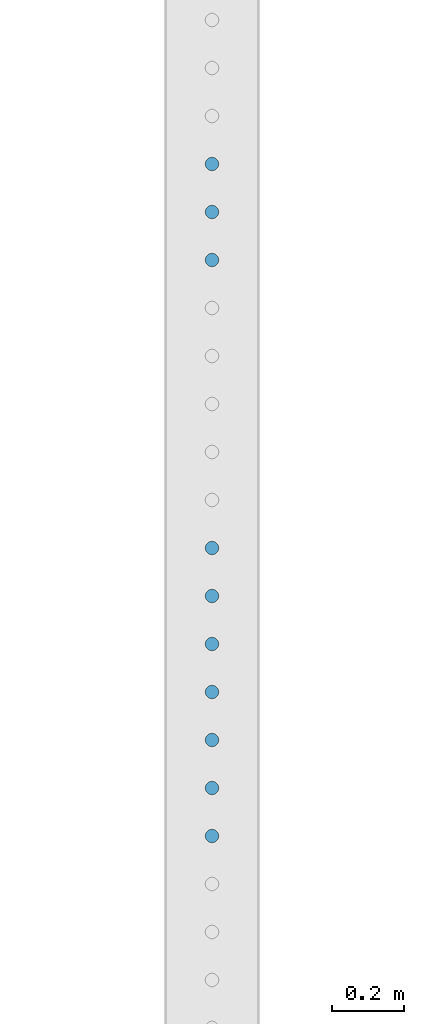
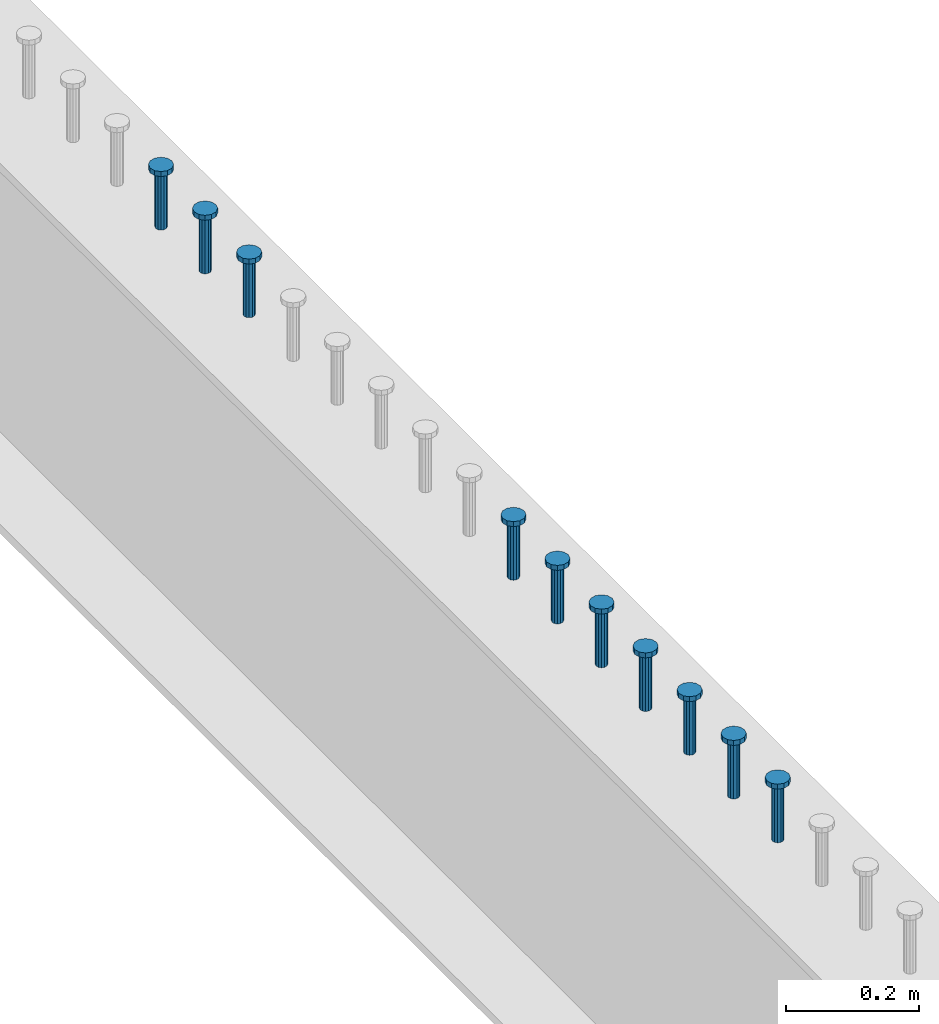
# One storey, part 943 of 1763: 10 columns, 10 elements without a shape of their own.
"""IFC2X3 building model written with IfcOpenShell, lengths in millimetres."""

from ifc_helpers import new_model, si_unit, frame, origin_with_axes, place, context, subcontext, project, spatial, faceted_brep, material, type_object, element, aggregate, save


model = new_model("IFC2X3")

# Units and contexts
model_context = context("Model", 3, precision=1e-05, world=origin_with_axes())
body_context = subcontext(model_context, "Body", "Model", "MODEL_VIEW")
ifc_project = project(units=[si_unit("LENGTHUNIT", "METRE", prefix="MILLI"), si_unit("AREAUNIT", "SQUARE_METRE"), si_unit("VOLUMEUNIT", "CUBIC_METRE"), si_unit("MASSUNIT", "GRAM", prefix="KILO"), si_unit("TIMEUNIT", "SECOND"), si_unit("PLANEANGLEUNIT", "RADIAN"), si_unit("SOLIDANGLEUNIT", "STERADIAN"), si_unit("THERMODYNAMICTEMPERATUREUNIT", "DEGREE_CELSIUS"), si_unit("LUMINOUSINTENSITYUNIT", "LUMEN")], contexts=[model_context])

# Site, building, storey
site_placement = place(None, origin_with_axes())
site = spatial("IfcSite", under=ifc_project, at=site_placement, CompositionType="ELEMENT")
building_placement = place(site_placement, origin_with_axes())
building = spatial("IfcBuilding", under=site, at=building_placement, Name="Undefined", CompositionType="ELEMENT")
storey_placement = place(building_placement, origin_with_axes())
storey = spatial("IfcBuildingStorey", under=building, at=storey_placement, Name="Undefined", CompositionType="ELEMENT", Elevation=0.0)

# Assembly, column
assembly_1_placement = place(storey_placement, origin_with_axes())
assembly_1 = element("IfcElementAssembly", 1, at=assembly_1_placement, inside=storey, Name="STUD", AssemblyPlace="NOTDEFINED", PredefinedType="RIGID_FRAME")
ifc_material = material(Name="STEEL/A108")
column_type = type_object("IfcColumnType", Name="STUD_3/4-DIA", PredefinedType="NOTDEFINED")
column_1_placement = place(assembly_1_placement, frame((-24027.8372736984, 35889.1985, 5194.3), z_axis=(-1.0, 0.0, 0.0), x_axis=(0.0, 0.0, 1.0)))
column_1 = element("IfcColumn", 2, at=column_1_placement, type_object=column_type, material=ifc_material, Name="STUD", ObjectType="STUD_3/4-DIA", context=body_context, shape_type="Brep", body=[
    faceted_brep([(0.0, -9.52000045776367, 0.0), (0.0, -8.25, -4.76000022888184), (104.013, -8.25, -4.76000022888184), (104.013, -9.52000045776367, 0.0), (0.0, -4.76000022888184, -8.25), (104.013, -4.76000022888184, -8.25), (0.0, 0.0, -9.52000045776367), (104.013, 0.0, -9.52000045776367), (0.0, 4.76000022888184, -8.25), (104.013, 4.76000022888184, -8.25), (0.0, 8.25, -4.76000022888184), (104.013, 8.25, -4.76000022888184), (0.0, 9.52000045776367, 0.0), (104.013, 9.52000045776367, 0.0), (0.0, 8.25, 4.76000022888184), (104.013, 8.25, 4.76000022888184), (0.0, 4.76000022888184, 8.25), (104.013, 4.76000022888184, 8.25), (0.0, 0.0, 9.52000045776367), (104.013, 0.0, 9.52000045776367), (0.0, -4.76000022888184, 8.25), (104.013, -4.76000022888184, 8.25), (0.0, -8.25, 4.76000022888184), (104.013, -8.25, 4.76000022888184), (105.156, -16.5, -9.52000045776367), (105.156, -19.0499992370605, 0.0), (105.156, -9.52000045776367, -16.5), (105.156, 0.0, -19.0499992370605), (105.156, 9.52000045776367, -16.5), (105.156, 16.5, -9.52000045776367), (105.156, 19.0499992370605, 0.0), (105.156, 16.5, 9.52000045776367), (105.156, 9.52000045776367, 16.5), (105.156, 0.0, 19.0499992370605), (105.156, -9.52000045776367, 16.5), (105.156, -16.5, 9.52000045776367), (114.3, -16.5, -9.52000045776367), (114.299998441489, -19.0500000000029, 0.0), (114.3, -9.52000045776367, -16.5), (114.3, 0.0, -19.0499992370605), (114.3, 9.52000045776367, -16.5), (114.3, 16.5, -9.52000045776367), (114.299998441489, 19.0500000000029, 0.0), (114.3, 16.5, 9.52000045776367), (114.3, 9.52000045776367, 16.5), (114.3, 0.0, 19.0499992370605), (114.3, -9.52000045776367, 16.5), (114.3, -16.5, 9.52000045776367)], [[[0, 1, 2, 3]], [[1, 4, 5, 2]], [[4, 6, 7, 5]], [[6, 8, 9, 7]], [[8, 10, 11, 9]], [[10, 12, 13, 11]], [[12, 14, 15, 13]], [[14, 16, 17, 15]], [[16, 18, 19, 17]], [[18, 20, 21, 19]], [[20, 22, 23, 21]], [[22, 0, 3, 23]], [[22, 20, 18, 16, 14, 12, 10, 8, 6, 4, 1, 0]], [[3, 2, 24, 25]], [[2, 5, 26, 24]], [[5, 7, 27, 26]], [[7, 9, 28, 27]], [[9, 11, 29, 28]], [[11, 13, 30, 29]], [[13, 15, 31, 30]], [[15, 17, 32, 31]], [[17, 19, 33, 32]], [[19, 21, 34, 33]], [[21, 23, 35, 34]], [[23, 3, 25, 35]], [[25, 24, 36, 37]], [[24, 26, 38, 36]], [[26, 27, 39, 38]], [[27, 28, 40, 39]], [[28, 29, 41, 40]], [[29, 30, 42, 41]], [[30, 31, 43, 42]], [[31, 32, 44, 43]], [[32, 33, 45, 44]], [[33, 34, 46, 45]], [[34, 35, 47, 46]], [[35, 25, 37, 47]], [[38, 39, 40, 41, 42, 43, 44, 45, 46, 47, 37, 36]]]),
])
aggregate(assembly_1, [column_1])

assembly_2_placement = place(storey_placement, origin_with_axes())
assembly_2 = element("IfcElementAssembly", 3, at=assembly_2_placement, inside=storey, Name="STUD", AssemblyPlace="NOTDEFINED", PredefinedType="RIGID_FRAME")
column_2_placement = place(assembly_2_placement, frame((-24027.8372736984, 35756.5905, 5194.3), z_axis=(-1.0, 0.0, 0.0), x_axis=(0.0, 0.0, 1.0)))
column_2 = element("IfcColumn", 4, at=column_2_placement, type_object=column_type, material=ifc_material, Name="STUD", ObjectType="STUD_3/4-DIA", context=body_context, shape_type="Brep", body=[
    faceted_brep([(0.0, -9.52000045776367, 0.0), (0.0, -8.25, -4.76000022888184), (104.013, -8.25, -4.76000022888184), (104.013, -9.52000045776367, 0.0), (0.0, -4.76000022888184, -8.25), (104.013, -4.76000022888184, -8.25), (0.0, 0.0, -9.52000045776367), (104.013, 0.0, -9.52000045776367), (0.0, 4.76000022888184, -8.25), (104.013, 4.76000022888184, -8.25), (0.0, 8.25, -4.76000022888184), (104.013, 8.25, -4.76000022888184), (0.0, 9.52000045776367, 0.0), (104.013, 9.52000045776367, 0.0), (0.0, 8.25, 4.76000022888184), (104.013, 8.25, 4.76000022888184), (0.0, 4.76000022888184, 8.25), (104.013, 4.76000022888184, 8.25), (0.0, 0.0, 9.52000045776367), (104.013, 0.0, 9.52000045776367), (0.0, -4.76000022888184, 8.25), (104.013, -4.76000022888184, 8.25), (0.0, -8.25, 4.76000022888184), (104.013, -8.25, 4.76000022888184), (105.156, -16.5, -9.52000045776367), (105.156, -19.0499992370605, 0.0), (105.156, -9.52000045776367, -16.5), (105.156, 0.0, -19.0499992370605), (105.156, 9.52000045776367, -16.5), (105.156, 16.5, -9.52000045776367), (105.156, 19.0499992370605, 0.0), (105.156, 16.5, 9.52000045776367), (105.156, 9.52000045776367, 16.5), (105.156, 0.0, 19.0499992370605), (105.156, -9.52000045776367, 16.5), (105.156, -16.5, 9.52000045776367), (114.3, -16.5, -9.52000045776367), (114.299998441489, -19.0500000000029, 0.0), (114.3, -9.52000045776367, -16.5), (114.3, 0.0, -19.0499992370605), (114.3, 9.52000045776367, -16.5), (114.3, 16.5, -9.52000045776367), (114.299998441489, 19.0500000000029, 0.0), (114.3, 16.5, 9.52000045776367), (114.3, 9.52000045776367, 16.5), (114.3, 0.0, 19.0499992370605), (114.3, -9.52000045776367, 16.5), (114.3, -16.5, 9.52000045776367)], [[[0, 1, 2, 3]], [[1, 4, 5, 2]], [[4, 6, 7, 5]], [[6, 8, 9, 7]], [[8, 10, 11, 9]], [[10, 12, 13, 11]], [[12, 14, 15, 13]], [[14, 16, 17, 15]], [[16, 18, 19, 17]], [[18, 20, 21, 19]], [[20, 22, 23, 21]], [[22, 0, 3, 23]], [[22, 20, 18, 16, 14, 12, 10, 8, 6, 4, 1, 0]], [[3, 2, 24, 25]], [[2, 5, 26, 24]], [[5, 7, 27, 26]], [[7, 9, 28, 27]], [[9, 11, 29, 28]], [[11, 13, 30, 29]], [[13, 15, 31, 30]], [[15, 17, 32, 31]], [[17, 19, 33, 32]], [[19, 21, 34, 33]], [[21, 23, 35, 34]], [[23, 3, 25, 35]], [[25, 24, 36, 37]], [[24, 26, 38, 36]], [[26, 27, 39, 38]], [[27, 28, 40, 39]], [[28, 29, 41, 40]], [[29, 30, 42, 41]], [[30, 31, 43, 42]], [[31, 32, 44, 43]], [[32, 33, 45, 44]], [[33, 34, 46, 45]], [[34, 35, 47, 46]], [[35, 25, 37, 47]], [[38, 39, 40, 41, 42, 43, 44, 45, 46, 47, 37, 36]]]),
])
aggregate(assembly_2, [column_2])

assembly_3_placement = place(storey_placement, origin_with_axes())
assembly_3 = element("IfcElementAssembly", 5, at=assembly_3_placement, inside=storey, Name="STUD", AssemblyPlace="NOTDEFINED", PredefinedType="RIGID_FRAME")
column_3_placement = place(assembly_3_placement, frame((-24027.8372736984, 35623.9825, 5194.3), z_axis=(-1.0, 0.0, 0.0), x_axis=(0.0, 0.0, 1.0)))
column_3 = element("IfcColumn", 6, at=column_3_placement, type_object=column_type, material=ifc_material, Name="STUD", ObjectType="STUD_3/4-DIA", context=body_context, shape_type="Brep", body=[
    faceted_brep([(0.0, -9.52000045776367, 0.0), (0.0, -8.25, -4.76000022888184), (104.013, -8.25, -4.76000022888184), (104.013, -9.52000045776367, 0.0), (0.0, -4.76000022888184, -8.25), (104.013, -4.76000022888184, -8.25), (0.0, 0.0, -9.52000045776367), (104.013, 0.0, -9.52000045776367), (0.0, 4.76000022888184, -8.25), (104.013, 4.76000022888184, -8.25), (0.0, 8.25, -4.76000022888184), (104.013, 8.25, -4.76000022888184), (0.0, 9.52000045776367, 0.0), (104.013, 9.52000045776367, 0.0), (0.0, 8.25, 4.76000022888184), (104.013, 8.25, 4.76000022888184), (0.0, 4.76000022888184, 8.25), (104.013, 4.76000022888184, 8.25), (0.0, 0.0, 9.52000045776367), (104.013, 0.0, 9.52000045776367), (0.0, -4.76000022888184, 8.25), (104.013, -4.76000022888184, 8.25), (0.0, -8.25, 4.76000022888184), (104.013, -8.25, 4.76000022888184), (105.156, -16.5, -9.52000045776367), (105.156, -19.0499992370605, 0.0), (105.156, -9.52000045776367, -16.5), (105.156, 0.0, -19.0499992370605), (105.156, 9.52000045776367, -16.5), (105.156, 16.5, -9.52000045776367), (105.156, 19.0499992370605, 0.0), (105.156, 16.5, 9.52000045776367), (105.156, 9.52000045776367, 16.5), (105.156, 0.0, 19.0499992370605), (105.156, -9.52000045776367, 16.5), (105.156, -16.5, 9.52000045776367), (114.3, -16.5, -9.52000045776367), (114.299998441489, -19.0500000000029, 0.0), (114.3, -9.52000045776367, -16.5), (114.3, 0.0, -19.0499992370605), (114.3, 9.52000045776367, -16.5), (114.3, 16.5, -9.52000045776367), (114.299998441489, 19.0500000000029, 0.0), (114.3, 16.5, 9.52000045776367), (114.3, 9.52000045776367, 16.5), (114.3, 0.0, 19.0499992370605), (114.3, -9.52000045776367, 16.5), (114.3, -16.5, 9.52000045776367)], [[[0, 1, 2, 3]], [[1, 4, 5, 2]], [[4, 6, 7, 5]], [[6, 8, 9, 7]], [[8, 10, 11, 9]], [[10, 12, 13, 11]], [[12, 14, 15, 13]], [[14, 16, 17, 15]], [[16, 18, 19, 17]], [[18, 20, 21, 19]], [[20, 22, 23, 21]], [[22, 0, 3, 23]], [[22, 20, 18, 16, 14, 12, 10, 8, 6, 4, 1, 0]], [[3, 2, 24, 25]], [[2, 5, 26, 24]], [[5, 7, 27, 26]], [[7, 9, 28, 27]], [[9, 11, 29, 28]], [[11, 13, 30, 29]], [[13, 15, 31, 30]], [[15, 17, 32, 31]], [[17, 19, 33, 32]], [[19, 21, 34, 33]], [[21, 23, 35, 34]], [[23, 3, 25, 35]], [[25, 24, 36, 37]], [[24, 26, 38, 36]], [[26, 27, 39, 38]], [[27, 28, 40, 39]], [[28, 29, 41, 40]], [[29, 30, 42, 41]], [[30, 31, 43, 42]], [[31, 32, 44, 43]], [[32, 33, 45, 44]], [[33, 34, 46, 45]], [[34, 35, 47, 46]], [[35, 25, 37, 47]], [[38, 39, 40, 41, 42, 43, 44, 45, 46, 47, 37, 36]]]),
])
aggregate(assembly_3, [column_3])

assembly_4_placement = place(storey_placement, origin_with_axes())
assembly_4 = element("IfcElementAssembly", 7, at=assembly_4_placement, inside=storey, Name="STUD", AssemblyPlace="NOTDEFINED", PredefinedType="RIGID_FRAME")
column_4_placement = place(assembly_4_placement, frame((-24027.8372736984, 34828.3345, 5194.3), z_axis=(-1.0, 0.0, 0.0), x_axis=(0.0, 0.0, 1.0)))
column_4 = element("IfcColumn", 8, at=column_4_placement, type_object=column_type, material=ifc_material, Name="STUD", ObjectType="STUD_3/4-DIA", context=body_context, shape_type="Brep", body=[
    faceted_brep([(0.0, -9.52000045776367, 0.0), (0.0, -8.25, -4.76000022888184), (104.013, -8.25, -4.76000022888184), (104.013, -9.52000045776367, 0.0), (0.0, -4.76000022888184, -8.25), (104.013, -4.76000022888184, -8.25), (0.0, 0.0, -9.52000045776367), (104.013, 0.0, -9.52000045776367), (0.0, 4.76000022888184, -8.25), (104.013, 4.76000022888184, -8.25), (0.0, 8.25, -4.76000022888184), (104.013, 8.25, -4.76000022888184), (0.0, 9.52000045776367, 0.0), (104.013, 9.52000045776367, 0.0), (0.0, 8.25, 4.76000022888184), (104.013, 8.25, 4.76000022888184), (0.0, 4.76000022888184, 8.25), (104.013, 4.76000022888184, 8.25), (0.0, 0.0, 9.52000045776367), (104.013, 0.0, 9.52000045776367), (0.0, -4.76000022888184, 8.25), (104.013, -4.76000022888184, 8.25), (0.0, -8.25, 4.76000022888184), (104.013, -8.25, 4.76000022888184), (105.156, -16.5, -9.52000045776367), (105.156, -19.0499992370605, 0.0), (105.156, -9.52000045776367, -16.5), (105.156, 0.0, -19.0499992370605), (105.156, 9.52000045776367, -16.5), (105.156, 16.5, -9.52000045776367), (105.156, 19.0499992370605, 0.0), (105.156, 16.5, 9.52000045776367), (105.156, 9.52000045776367, 16.5), (105.156, 0.0, 19.0499992370605), (105.156, -9.52000045776367, 16.5), (105.156, -16.5, 9.52000045776367), (114.3, -16.5, -9.52000045776367), (114.299998441489, -19.0500000000029, 0.0), (114.3, -9.52000045776367, -16.5), (114.3, 0.0, -19.0499992370605), (114.3, 9.52000045776367, -16.5), (114.3, 16.5, -9.52000045776367), (114.299998441489, 19.0500000000029, 0.0), (114.3, 16.5, 9.52000045776367), (114.3, 9.52000045776367, 16.5), (114.3, 0.0, 19.0499992370605), (114.3, -9.52000045776367, 16.5), (114.3, -16.5, 9.52000045776367)], [[[0, 1, 2, 3]], [[1, 4, 5, 2]], [[4, 6, 7, 5]], [[6, 8, 9, 7]], [[8, 10, 11, 9]], [[10, 12, 13, 11]], [[12, 14, 15, 13]], [[14, 16, 17, 15]], [[16, 18, 19, 17]], [[18, 20, 21, 19]], [[20, 22, 23, 21]], [[22, 0, 3, 23]], [[22, 20, 18, 16, 14, 12, 10, 8, 6, 4, 1, 0]], [[3, 2, 24, 25]], [[2, 5, 26, 24]], [[5, 7, 27, 26]], [[7, 9, 28, 27]], [[9, 11, 29, 28]], [[11, 13, 30, 29]], [[13, 15, 31, 30]], [[15, 17, 32, 31]], [[17, 19, 33, 32]], [[19, 21, 34, 33]], [[21, 23, 35, 34]], [[23, 3, 25, 35]], [[25, 24, 36, 37]], [[24, 26, 38, 36]], [[26, 27, 39, 38]], [[27, 28, 40, 39]], [[28, 29, 41, 40]], [[29, 30, 42, 41]], [[30, 31, 43, 42]], [[31, 32, 44, 43]], [[32, 33, 45, 44]], [[33, 34, 46, 45]], [[34, 35, 47, 46]], [[35, 25, 37, 47]], [[38, 39, 40, 41, 42, 43, 44, 45, 46, 47, 37, 36]]]),
])
aggregate(assembly_4, [column_4])

assembly_5_placement = place(storey_placement, origin_with_axes())
assembly_5 = element("IfcElementAssembly", 9, at=assembly_5_placement, inside=storey, Name="STUD", AssemblyPlace="NOTDEFINED", PredefinedType="RIGID_FRAME")
column_5_placement = place(assembly_5_placement, frame((-24027.8372736984, 34695.7265, 5194.3), z_axis=(-1.0, 0.0, 0.0), x_axis=(0.0, 0.0, 1.0)))
column_5 = element("IfcColumn", 10, at=column_5_placement, type_object=column_type, material=ifc_material, Name="STUD", ObjectType="STUD_3/4-DIA", context=body_context, shape_type="Brep", body=[
    faceted_brep([(0.0, -9.52000045776367, 0.0), (0.0, -8.25, -4.76000022888184), (104.013, -8.25, -4.76000022888184), (104.013, -9.52000045776367, 0.0), (0.0, -4.76000022888184, -8.25), (104.013, -4.76000022888184, -8.25), (0.0, 0.0, -9.52000045776367), (104.013, 0.0, -9.52000045776367), (0.0, 4.76000022888184, -8.25), (104.013, 4.76000022888184, -8.25), (0.0, 8.25, -4.76000022888184), (104.013, 8.25, -4.76000022888184), (0.0, 9.52000045776367, 0.0), (104.013, 9.52000045776367, 0.0), (0.0, 8.25, 4.76000022888184), (104.013, 8.25, 4.76000022888184), (0.0, 4.76000022888184, 8.25), (104.013, 4.76000022888184, 8.25), (0.0, 0.0, 9.52000045776367), (104.013, 0.0, 9.52000045776367), (0.0, -4.76000022888184, 8.25), (104.013, -4.76000022888184, 8.25), (0.0, -8.25, 4.76000022888184), (104.013, -8.25, 4.76000022888184), (105.156, -16.5, -9.52000045776367), (105.156, -19.0499992370605, 0.0), (105.156, -9.52000045776367, -16.5), (105.156, 0.0, -19.0499992370605), (105.156, 9.52000045776367, -16.5), (105.156, 16.5, -9.52000045776367), (105.156, 19.0499992370605, 0.0), (105.156, 16.5, 9.52000045776367), (105.156, 9.52000045776367, 16.5), (105.156, 0.0, 19.0499992370605), (105.156, -9.52000045776367, 16.5), (105.156, -16.5, 9.52000045776367), (114.3, -16.5, -9.52000045776367), (114.299998441489, -19.0500000000029, 0.0), (114.3, -9.52000045776367, -16.5), (114.3, 0.0, -19.0499992370605), (114.3, 9.52000045776367, -16.5), (114.3, 16.5, -9.52000045776367), (114.299998441489, 19.0500000000029, 0.0), (114.3, 16.5, 9.52000045776367), (114.3, 9.52000045776367, 16.5), (114.3, 0.0, 19.0499992370605), (114.3, -9.52000045776367, 16.5), (114.3, -16.5, 9.52000045776367)], [[[0, 1, 2, 3]], [[1, 4, 5, 2]], [[4, 6, 7, 5]], [[6, 8, 9, 7]], [[8, 10, 11, 9]], [[10, 12, 13, 11]], [[12, 14, 15, 13]], [[14, 16, 17, 15]], [[16, 18, 19, 17]], [[18, 20, 21, 19]], [[20, 22, 23, 21]], [[22, 0, 3, 23]], [[22, 20, 18, 16, 14, 12, 10, 8, 6, 4, 1, 0]], [[3, 2, 24, 25]], [[2, 5, 26, 24]], [[5, 7, 27, 26]], [[7, 9, 28, 27]], [[9, 11, 29, 28]], [[11, 13, 30, 29]], [[13, 15, 31, 30]], [[15, 17, 32, 31]], [[17, 19, 33, 32]], [[19, 21, 34, 33]], [[21, 23, 35, 34]], [[23, 3, 25, 35]], [[25, 24, 36, 37]], [[24, 26, 38, 36]], [[26, 27, 39, 38]], [[27, 28, 40, 39]], [[28, 29, 41, 40]], [[29, 30, 42, 41]], [[30, 31, 43, 42]], [[31, 32, 44, 43]], [[32, 33, 45, 44]], [[33, 34, 46, 45]], [[34, 35, 47, 46]], [[35, 25, 37, 47]], [[38, 39, 40, 41, 42, 43, 44, 45, 46, 47, 37, 36]]]),
])
aggregate(assembly_5, [column_5])

assembly_6_placement = place(storey_placement, origin_with_axes())
assembly_6 = element("IfcElementAssembly", 11, at=assembly_6_placement, inside=storey, Name="STUD", AssemblyPlace="NOTDEFINED", PredefinedType="RIGID_FRAME")
column_6_placement = place(assembly_6_placement, frame((-24027.8372736984, 34563.1185, 5194.3), z_axis=(-1.0, 0.0, 0.0), x_axis=(0.0, 0.0, 1.0)))
column_6 = element("IfcColumn", 12, at=column_6_placement, type_object=column_type, material=ifc_material, Name="STUD", ObjectType="STUD_3/4-DIA", context=body_context, shape_type="Brep", body=[
    faceted_brep([(0.0, -9.52000045776367, 0.0), (0.0, -8.25, -4.76000022888184), (104.013, -8.25, -4.76000022888184), (104.013, -9.52000045776367, 0.0), (0.0, -4.76000022888184, -8.25), (104.013, -4.76000022888184, -8.25), (0.0, 0.0, -9.52000045776367), (104.013, 0.0, -9.52000045776367), (0.0, 4.76000022888184, -8.25), (104.013, 4.76000022888184, -8.25), (0.0, 8.25, -4.76000022888184), (104.013, 8.25, -4.76000022888184), (0.0, 9.52000045776367, 0.0), (104.013, 9.52000045776367, 0.0), (0.0, 8.25, 4.76000022888184), (104.013, 8.25, 4.76000022888184), (0.0, 4.76000022888184, 8.25), (104.013, 4.76000022888184, 8.25), (0.0, 0.0, 9.52000045776367), (104.013, 0.0, 9.52000045776367), (0.0, -4.76000022888184, 8.25), (104.013, -4.76000022888184, 8.25), (0.0, -8.25, 4.76000022888184), (104.013, -8.25, 4.76000022888184), (105.156, -16.5, -9.52000045776367), (105.156, -19.0499992370605, 0.0), (105.156, -9.52000045776367, -16.5), (105.156, 0.0, -19.0499992370605), (105.156, 9.52000045776367, -16.5), (105.156, 16.5, -9.52000045776367), (105.156, 19.0499992370605, 0.0), (105.156, 16.5, 9.52000045776367), (105.156, 9.52000045776367, 16.5), (105.156, 0.0, 19.0499992370605), (105.156, -9.52000045776367, 16.5), (105.156, -16.5, 9.52000045776367), (114.3, -16.5, -9.52000045776367), (114.299998441489, -19.0500000000029, 0.0), (114.3, -9.52000045776367, -16.5), (114.3, 0.0, -19.0499992370605), (114.3, 9.52000045776367, -16.5), (114.3, 16.5, -9.52000045776367), (114.299998441489, 19.0500000000029, 0.0), (114.3, 16.5, 9.52000045776367), (114.3, 9.52000045776367, 16.5), (114.3, 0.0, 19.0499992370605), (114.3, -9.52000045776367, 16.5), (114.3, -16.5, 9.52000045776367)], [[[0, 1, 2, 3]], [[1, 4, 5, 2]], [[4, 6, 7, 5]], [[6, 8, 9, 7]], [[8, 10, 11, 9]], [[10, 12, 13, 11]], [[12, 14, 15, 13]], [[14, 16, 17, 15]], [[16, 18, 19, 17]], [[18, 20, 21, 19]], [[20, 22, 23, 21]], [[22, 0, 3, 23]], [[22, 20, 18, 16, 14, 12, 10, 8, 6, 4, 1, 0]], [[3, 2, 24, 25]], [[2, 5, 26, 24]], [[5, 7, 27, 26]], [[7, 9, 28, 27]], [[9, 11, 29, 28]], [[11, 13, 30, 29]], [[13, 15, 31, 30]], [[15, 17, 32, 31]], [[17, 19, 33, 32]], [[19, 21, 34, 33]], [[21, 23, 35, 34]], [[23, 3, 25, 35]], [[25, 24, 36, 37]], [[24, 26, 38, 36]], [[26, 27, 39, 38]], [[27, 28, 40, 39]], [[28, 29, 41, 40]], [[29, 30, 42, 41]], [[30, 31, 43, 42]], [[31, 32, 44, 43]], [[32, 33, 45, 44]], [[33, 34, 46, 45]], [[34, 35, 47, 46]], [[35, 25, 37, 47]], [[38, 39, 40, 41, 42, 43, 44, 45, 46, 47, 37, 36]]]),
])
aggregate(assembly_6, [column_6])

assembly_7_placement = place(storey_placement, origin_with_axes())
assembly_7 = element("IfcElementAssembly", 13, at=assembly_7_placement, inside=storey, Name="STUD", AssemblyPlace="NOTDEFINED", PredefinedType="RIGID_FRAME")
column_7_placement = place(assembly_7_placement, frame((-24027.8372736984, 34430.5105, 5194.3), z_axis=(-1.0, 0.0, 0.0), x_axis=(0.0, 0.0, 1.0)))
column_7 = element("IfcColumn", 14, at=column_7_placement, type_object=column_type, material=ifc_material, Name="STUD", ObjectType="STUD_3/4-DIA", context=body_context, shape_type="Brep", body=[
    faceted_brep([(0.0, -9.52000045776367, 0.0), (0.0, -8.25, -4.76000022888184), (104.013, -8.25, -4.76000022888184), (104.013, -9.52000045776367, 0.0), (0.0, -4.76000022888184, -8.25), (104.013, -4.76000022888184, -8.25), (0.0, 0.0, -9.52000045776367), (104.013, 0.0, -9.52000045776367), (0.0, 4.76000022888184, -8.25), (104.013, 4.76000022888184, -8.25), (0.0, 8.25, -4.76000022888184), (104.013, 8.25, -4.76000022888184), (0.0, 9.52000045776367, 0.0), (104.013, 9.52000045776367, 0.0), (0.0, 8.25, 4.76000022888184), (104.013, 8.25, 4.76000022888184), (0.0, 4.76000022888184, 8.25), (104.013, 4.76000022888184, 8.25), (0.0, 0.0, 9.52000045776367), (104.013, 0.0, 9.52000045776367), (0.0, -4.76000022888184, 8.25), (104.013, -4.76000022888184, 8.25), (0.0, -8.25, 4.76000022888184), (104.013, -8.25, 4.76000022888184), (105.156, -16.5, -9.52000045776367), (105.156, -19.0499992370605, 0.0), (105.156, -9.52000045776367, -16.5), (105.156, 0.0, -19.0499992370605), (105.156, 9.52000045776367, -16.5), (105.156, 16.5, -9.52000045776367), (105.156, 19.0499992370605, 0.0), (105.156, 16.5, 9.52000045776367), (105.156, 9.52000045776367, 16.5), (105.156, 0.0, 19.0499992370605), (105.156, -9.52000045776367, 16.5), (105.156, -16.5, 9.52000045776367), (114.3, -16.5, -9.52000045776367), (114.299998441489, -19.0500000000029, 0.0), (114.3, -9.52000045776367, -16.5), (114.3, 0.0, -19.0499992370605), (114.3, 9.52000045776367, -16.5), (114.3, 16.5, -9.52000045776367), (114.299998441489, 19.0500000000029, 0.0), (114.3, 16.5, 9.52000045776367), (114.3, 9.52000045776367, 16.5), (114.3, 0.0, 19.0499992370605), (114.3, -9.52000045776367, 16.5), (114.3, -16.5, 9.52000045776367)], [[[0, 1, 2, 3]], [[1, 4, 5, 2]], [[4, 6, 7, 5]], [[6, 8, 9, 7]], [[8, 10, 11, 9]], [[10, 12, 13, 11]], [[12, 14, 15, 13]], [[14, 16, 17, 15]], [[16, 18, 19, 17]], [[18, 20, 21, 19]], [[20, 22, 23, 21]], [[22, 0, 3, 23]], [[22, 20, 18, 16, 14, 12, 10, 8, 6, 4, 1, 0]], [[3, 2, 24, 25]], [[2, 5, 26, 24]], [[5, 7, 27, 26]], [[7, 9, 28, 27]], [[9, 11, 29, 28]], [[11, 13, 30, 29]], [[13, 15, 31, 30]], [[15, 17, 32, 31]], [[17, 19, 33, 32]], [[19, 21, 34, 33]], [[21, 23, 35, 34]], [[23, 3, 25, 35]], [[25, 24, 36, 37]], [[24, 26, 38, 36]], [[26, 27, 39, 38]], [[27, 28, 40, 39]], [[28, 29, 41, 40]], [[29, 30, 42, 41]], [[30, 31, 43, 42]], [[31, 32, 44, 43]], [[32, 33, 45, 44]], [[33, 34, 46, 45]], [[34, 35, 47, 46]], [[35, 25, 37, 47]], [[38, 39, 40, 41, 42, 43, 44, 45, 46, 47, 37, 36]]]),
])
aggregate(assembly_7, [column_7])

assembly_8_placement = place(storey_placement, origin_with_axes())
assembly_8 = element("IfcElementAssembly", 15, at=assembly_8_placement, inside=storey, Name="STUD", AssemblyPlace="NOTDEFINED", PredefinedType="RIGID_FRAME")
column_8_placement = place(assembly_8_placement, frame((-24027.8372736984, 34297.9025, 5194.3), z_axis=(-1.0, 0.0, 0.0), x_axis=(0.0, 0.0, 1.0)))
column_8 = element("IfcColumn", 16, at=column_8_placement, type_object=column_type, material=ifc_material, Name="STUD", ObjectType="STUD_3/4-DIA", context=body_context, shape_type="Brep", body=[
    faceted_brep([(0.0, -9.52000045776367, 0.0), (0.0, -8.25, -4.76000022888184), (104.013, -8.25, -4.76000022888184), (104.013, -9.52000045776367, 0.0), (0.0, -4.76000022888184, -8.25), (104.013, -4.76000022888184, -8.25), (0.0, 0.0, -9.52000045776367), (104.013, 0.0, -9.52000045776367), (0.0, 4.76000022888184, -8.25), (104.013, 4.76000022888184, -8.25), (0.0, 8.25, -4.76000022888184), (104.013, 8.25, -4.76000022888184), (0.0, 9.52000045776367, 0.0), (104.013, 9.52000045776367, 0.0), (0.0, 8.25, 4.76000022888184), (104.013, 8.25, 4.76000022888184), (0.0, 4.76000022888184, 8.25), (104.013, 4.76000022888184, 8.25), (0.0, 0.0, 9.52000045776367), (104.013, 0.0, 9.52000045776367), (0.0, -4.76000022888184, 8.25), (104.013, -4.76000022888184, 8.25), (0.0, -8.25, 4.76000022888184), (104.013, -8.25, 4.76000022888184), (105.156, -16.5, -9.52000045776367), (105.156, -19.0499992370605, 0.0), (105.156, -9.52000045776367, -16.5), (105.156, 0.0, -19.0499992370605), (105.156, 9.52000045776367, -16.5), (105.156, 16.5, -9.52000045776367), (105.156, 19.0499992370605, 0.0), (105.156, 16.5, 9.52000045776367), (105.156, 9.52000045776367, 16.5), (105.156, 0.0, 19.0499992370605), (105.156, -9.52000045776367, 16.5), (105.156, -16.5, 9.52000045776367), (114.3, -16.5, -9.52000045776367), (114.299998441489, -19.0500000000029, 0.0), (114.3, -9.52000045776367, -16.5), (114.3, 0.0, -19.0499992370605), (114.3, 9.52000045776367, -16.5), (114.3, 16.5, -9.52000045776367), (114.299998441489, 19.0500000000029, 0.0), (114.3, 16.5, 9.52000045776367), (114.3, 9.52000045776367, 16.5), (114.3, 0.0, 19.0499992370605), (114.3, -9.52000045776367, 16.5), (114.3, -16.5, 9.52000045776367)], [[[0, 1, 2, 3]], [[1, 4, 5, 2]], [[4, 6, 7, 5]], [[6, 8, 9, 7]], [[8, 10, 11, 9]], [[10, 12, 13, 11]], [[12, 14, 15, 13]], [[14, 16, 17, 15]], [[16, 18, 19, 17]], [[18, 20, 21, 19]], [[20, 22, 23, 21]], [[22, 0, 3, 23]], [[22, 20, 18, 16, 14, 12, 10, 8, 6, 4, 1, 0]], [[3, 2, 24, 25]], [[2, 5, 26, 24]], [[5, 7, 27, 26]], [[7, 9, 28, 27]], [[9, 11, 29, 28]], [[11, 13, 30, 29]], [[13, 15, 31, 30]], [[15, 17, 32, 31]], [[17, 19, 33, 32]], [[19, 21, 34, 33]], [[21, 23, 35, 34]], [[23, 3, 25, 35]], [[25, 24, 36, 37]], [[24, 26, 38, 36]], [[26, 27, 39, 38]], [[27, 28, 40, 39]], [[28, 29, 41, 40]], [[29, 30, 42, 41]], [[30, 31, 43, 42]], [[31, 32, 44, 43]], [[32, 33, 45, 44]], [[33, 34, 46, 45]], [[34, 35, 47, 46]], [[35, 25, 37, 47]], [[38, 39, 40, 41, 42, 43, 44, 45, 46, 47, 37, 36]]]),
])
aggregate(assembly_8, [column_8])

assembly_9_placement = place(storey_placement, origin_with_axes())
assembly_9 = element("IfcElementAssembly", 17, at=assembly_9_placement, inside=storey, Name="STUD", AssemblyPlace="NOTDEFINED", PredefinedType="RIGID_FRAME")
column_9_placement = place(assembly_9_placement, frame((-24027.8372736984, 34165.2945, 5194.3), z_axis=(-1.0, 0.0, 0.0), x_axis=(0.0, 0.0, 1.0)))
column_9 = element("IfcColumn", 18, at=column_9_placement, type_object=column_type, material=ifc_material, Name="STUD", ObjectType="STUD_3/4-DIA", context=body_context, shape_type="Brep", body=[
    faceted_brep([(0.0, -9.52000045776367, 0.0), (0.0, -8.25, -4.76000022888184), (104.013, -8.25, -4.76000022888184), (104.013, -9.52000045776367, 0.0), (0.0, -4.76000022888184, -8.25), (104.013, -4.76000022888184, -8.25), (0.0, 0.0, -9.52000045776367), (104.013, 0.0, -9.52000045776367), (0.0, 4.76000022888184, -8.25), (104.013, 4.76000022888184, -8.25), (0.0, 8.25, -4.76000022888184), (104.013, 8.25, -4.76000022888184), (0.0, 9.52000045776367, 0.0), (104.013, 9.52000045776367, 0.0), (0.0, 8.25, 4.76000022888184), (104.013, 8.25, 4.76000022888184), (0.0, 4.76000022888184, 8.25), (104.013, 4.76000022888184, 8.25), (0.0, 0.0, 9.52000045776367), (104.013, 0.0, 9.52000045776367), (0.0, -4.76000022888184, 8.25), (104.013, -4.76000022888184, 8.25), (0.0, -8.25, 4.76000022888184), (104.013, -8.25, 4.76000022888184), (105.156, -16.5, -9.52000045776367), (105.156, -19.0499992370605, 0.0), (105.156, -9.52000045776367, -16.5), (105.156, 0.0, -19.0499992370605), (105.156, 9.52000045776367, -16.5), (105.156, 16.5, -9.52000045776367), (105.156, 19.0499992370605, 0.0), (105.156, 16.5, 9.52000045776367), (105.156, 9.52000045776367, 16.5), (105.156, 0.0, 19.0499992370605), (105.156, -9.52000045776367, 16.5), (105.156, -16.5, 9.52000045776367), (114.3, -16.5, -9.52000045776367), (114.299998441489, -19.0500000000029, 0.0), (114.3, -9.52000045776367, -16.5), (114.3, 0.0, -19.0499992370605), (114.3, 9.52000045776367, -16.5), (114.3, 16.5, -9.52000045776367), (114.299998441489, 19.0500000000029, 0.0), (114.3, 16.5, 9.52000045776367), (114.3, 9.52000045776367, 16.5), (114.3, 0.0, 19.0499992370605), (114.3, -9.52000045776367, 16.5), (114.3, -16.5, 9.52000045776367)], [[[0, 1, 2, 3]], [[1, 4, 5, 2]], [[4, 6, 7, 5]], [[6, 8, 9, 7]], [[8, 10, 11, 9]], [[10, 12, 13, 11]], [[12, 14, 15, 13]], [[14, 16, 17, 15]], [[16, 18, 19, 17]], [[18, 20, 21, 19]], [[20, 22, 23, 21]], [[22, 0, 3, 23]], [[22, 20, 18, 16, 14, 12, 10, 8, 6, 4, 1, 0]], [[3, 2, 24, 25]], [[2, 5, 26, 24]], [[5, 7, 27, 26]], [[7, 9, 28, 27]], [[9, 11, 29, 28]], [[11, 13, 30, 29]], [[13, 15, 31, 30]], [[15, 17, 32, 31]], [[17, 19, 33, 32]], [[19, 21, 34, 33]], [[21, 23, 35, 34]], [[23, 3, 25, 35]], [[25, 24, 36, 37]], [[24, 26, 38, 36]], [[26, 27, 39, 38]], [[27, 28, 40, 39]], [[28, 29, 41, 40]], [[29, 30, 42, 41]], [[30, 31, 43, 42]], [[31, 32, 44, 43]], [[32, 33, 45, 44]], [[33, 34, 46, 45]], [[34, 35, 47, 46]], [[35, 25, 37, 47]], [[38, 39, 40, 41, 42, 43, 44, 45, 46, 47, 37, 36]]]),
])
aggregate(assembly_9, [column_9])

assembly_10_placement = place(storey_placement, origin_with_axes())
assembly_10 = element("IfcElementAssembly", 19, at=assembly_10_placement, inside=storey, Name="STUD", AssemblyPlace="NOTDEFINED", PredefinedType="RIGID_FRAME")
column_10_placement = place(assembly_10_placement, frame((-24027.8372736984, 34032.6865, 5194.3), z_axis=(-1.0, 0.0, 0.0), x_axis=(0.0, 0.0, 1.0)))
column_10 = element("IfcColumn", 20, at=column_10_placement, type_object=column_type, material=ifc_material, Name="STUD", ObjectType="STUD_3/4-DIA", context=body_context, shape_type="Brep", body=[
    faceted_brep([(0.0, -9.52000045776367, 0.0), (0.0, -8.25, -4.76000022888184), (104.013, -8.25, -4.76000022888184), (104.013, -9.52000045776367, 0.0), (0.0, -4.76000022888184, -8.25), (104.013, -4.76000022888184, -8.25), (0.0, 0.0, -9.52000045776367), (104.013, 0.0, -9.52000045776367), (0.0, 4.76000022888184, -8.25), (104.013, 4.76000022888184, -8.25), (0.0, 8.25, -4.76000022888184), (104.013, 8.25, -4.76000022888184), (0.0, 9.52000045776367, 0.0), (104.013, 9.52000045776367, 0.0), (0.0, 8.25, 4.76000022888184), (104.013, 8.25, 4.76000022888184), (0.0, 4.76000022888184, 8.25), (104.013, 4.76000022888184, 8.25), (0.0, 0.0, 9.52000045776367), (104.013, 0.0, 9.52000045776367), (0.0, -4.76000022888184, 8.25), (104.013, -4.76000022888184, 8.25), (0.0, -8.25, 4.76000022888184), (104.013, -8.25, 4.76000022888184), (105.156, -16.5, -9.52000045776367), (105.156, -19.0499992370605, 0.0), (105.156, -9.52000045776367, -16.5), (105.156, 0.0, -19.0499992370605), (105.156, 9.52000045776367, -16.5), (105.156, 16.5, -9.52000045776367), (105.156, 19.0499992370605, 0.0), (105.156, 16.5, 9.52000045776367), (105.156, 9.52000045776367, 16.5), (105.156, 0.0, 19.0499992370605), (105.156, -9.52000045776367, 16.5), (105.156, -16.5, 9.52000045776367), (114.3, -16.5, -9.52000045776367), (114.299998441489, -19.0500000000029, 0.0), (114.3, -9.52000045776367, -16.5), (114.3, 0.0, -19.0499992370605), (114.3, 9.52000045776367, -16.5), (114.3, 16.5, -9.52000045776367), (114.299998441489, 19.0500000000029, 0.0), (114.3, 16.5, 9.52000045776367), (114.3, 9.52000045776367, 16.5), (114.3, 0.0, 19.0499992370605), (114.3, -9.52000045776367, 16.5), (114.3, -16.5, 9.52000045776367)], [[[0, 1, 2, 3]], [[1, 4, 5, 2]], [[4, 6, 7, 5]], [[6, 8, 9, 7]], [[8, 10, 11, 9]], [[10, 12, 13, 11]], [[12, 14, 15, 13]], [[14, 16, 17, 15]], [[16, 18, 19, 17]], [[18, 20, 21, 19]], [[20, 22, 23, 21]], [[22, 0, 3, 23]], [[22, 20, 18, 16, 14, 12, 10, 8, 6, 4, 1, 0]], [[3, 2, 24, 25]], [[2, 5, 26, 24]], [[5, 7, 27, 26]], [[7, 9, 28, 27]], [[9, 11, 29, 28]], [[11, 13, 30, 29]], [[13, 15, 31, 30]], [[15, 17, 32, 31]], [[17, 19, 33, 32]], [[19, 21, 34, 33]], [[21, 23, 35, 34]], [[23, 3, 25, 35]], [[25, 24, 36, 37]], [[24, 26, 38, 36]], [[26, 27, 39, 38]], [[27, 28, 40, 39]], [[28, 29, 41, 40]], [[29, 30, 42, 41]], [[30, 31, 43, 42]], [[31, 32, 44, 43]], [[32, 33, 45, 44]], [[33, 34, 46, 45]], [[34, 35, 47, 46]], [[35, 25, 37, 47]], [[38, 39, 40, 41, 42, 43, 44, 45, 46, 47, 37, 36]]]),
])
aggregate(assembly_10, [column_10])

save(model, "model.ifc")
